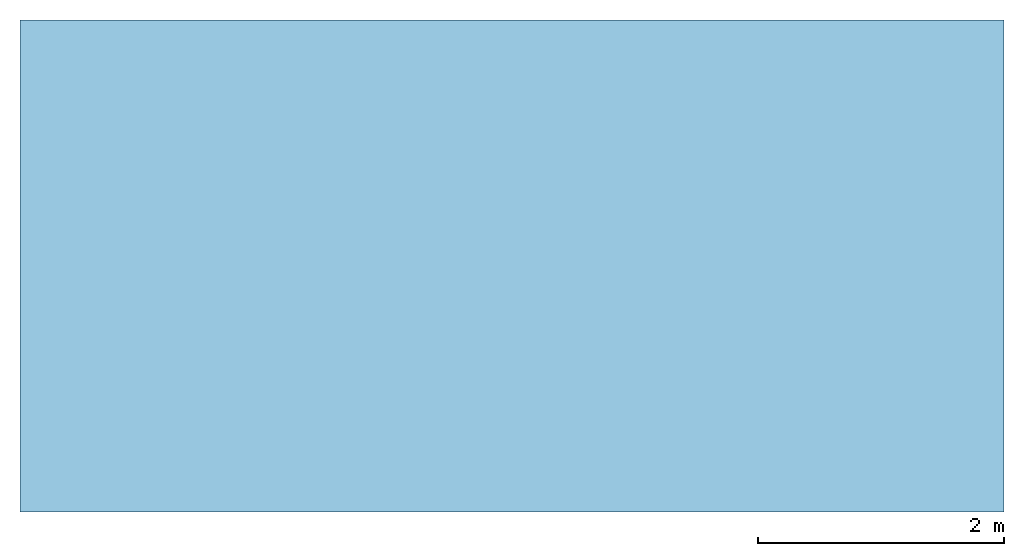
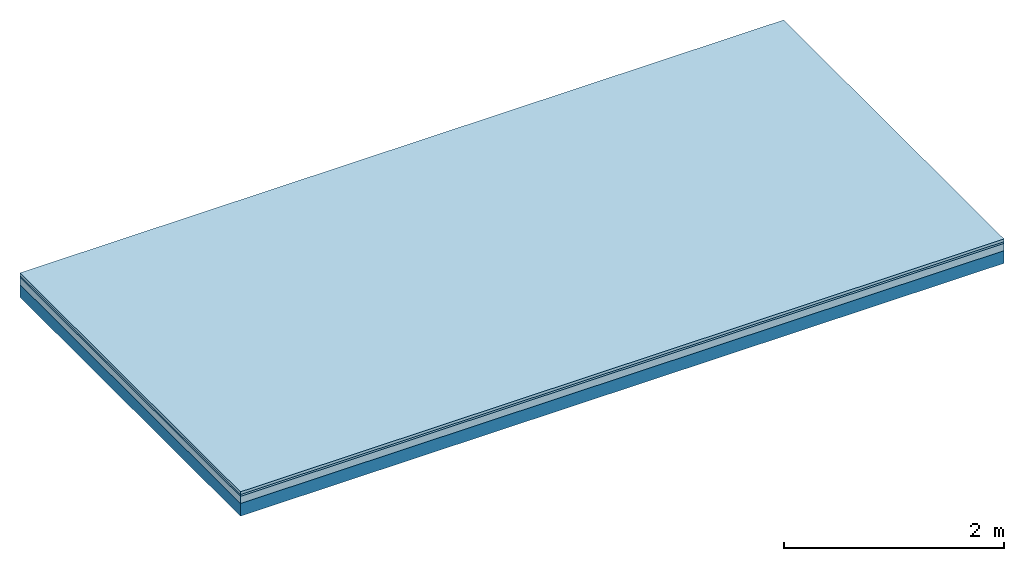
# One storey: 3 plates, 1 member, 1 element without a shape of its own.
"""IFC4 building model written with IfcOpenShell, lengths in metres."""

from ifc_helpers import new_model, si_unit, derived_unit, direction, frame, frame_2d, origin, origin_with_axes, place, context, project, spatial, rectangle, extrude, material, layer, layer_set, type_object, element, aggregate, save


model = new_model("IFC4")

# Units and contexts
plan_context = context("Plan", 3, precision=1e-05, world=origin(), true_north=direction((0.0, 1.0)))
model_context = context("Model", 3, precision=1e-05, world=origin(), true_north=direction((0.0, 1.0)))
ifc_project = project(units=[si_unit("LENGTHUNIT", "METRE"), derived_unit("SOUNDPRESSUREUNIT", [(si_unit("PRESSUREUNIT", "PASCAL", prefix="MICRO"), 0)]), si_unit("ENERGYUNIT", "JOULE", prefix="MEGA"), si_unit("MASSUNIT", "GRAM", prefix="KILO"), derived_unit("THERMALTRANSMITTANCEUNIT", [(si_unit("POWERUNIT", "WATT"), 1), (si_unit("AREAUNIT", "SQUARE_METRE"), -1), (si_unit("THERMODYNAMICTEMPERATUREUNIT", "KELVIN"), -1)]), derived_unit("AREADENSITYUNIT", [(si_unit("MASSUNIT", "GRAM", prefix="KILO"), 1), (si_unit("AREAUNIT", "SQUARE_METRE"), -1)]), derived_unit("USERDEFINED", [(si_unit("ENERGYUNIT", "JOULE", prefix="MEGA"), 1), (si_unit("AREAUNIT", "SQUARE_METRE"), -1)])], contexts=[plan_context, model_context])

# Site, building, storey
site = spatial("IfcSite", under=ifc_project)
building_placement = place(None, origin())
building = spatial("IfcBuilding", under=site, at=building_placement)
storey_placement = place(building_placement, origin())
storey = spatial("IfcBuildingStorey", under=building, at=storey_placement)

# Slab, member, plates
ifc_material_1 = material(Name="Phone Star TRI", Category="03.013")
ifc_layer_1 = layer(ifc_material_1, 0.03, Name="On-material")
ifc_material_2 = material(Name="EP3")
ifc_layer_2 = layer(ifc_material_2, 0.02, Name="Impact sound insulation")
ifc_material_3 = material(Category="03.011")
ifc_layer_3 = layer(ifc_material_3, 0.08, Name="on Supporting structure")
ifc_material_4 = material(Name="no composite action")
ifc_layer_4 = layer(ifc_material_4, 0.0, Name="Bond")
ifc_layer_5 = layer(None, 0.14, Name="Supporting structure")
ifc_layer_set = layer_set([ifc_layer_1, ifc_layer_2, ifc_layer_3, ifc_layer_4, ifc_layer_5])
slab_type = type_object("IfcSlabType", Name="A2424", PredefinedType="NOTDEFINED", material=ifc_layer_set)
slab_placement = place(None, frame((0.0, 0.0, 0.0), z_axis=(0.0, 0.0, -1.0), x_axis=(1.0, 0.0, 0.0)))
slab = element("IfcSlab", 1, at=slab_placement, inside=storey, type_object=slab_type, material=ifc_layer_set, Name="Slab #1")
ifc_material_5 = material()
member_placement = place(slab_placement, origin())
member = element("IfcMember", 2, at=member_placement, material=ifc_material_5, Name="Supporting structure", context=plan_context, shape_type="SweptSolid", body=[
    extrude(rectangle(XDim=1.0, YDim=0.14, at=frame_2d((0.5, 0.07), x_axis=(1.0, 0.0))), frame((0.0, 4.0, 0.13), z_axis=(0.0, -1.0, 0.0), x_axis=(1.0, 0.0, 0.0)), (0.0, 0.0, 1.0), 4.0),
    extrude(rectangle(XDim=1.0, YDim=0.14, at=frame_2d((0.5, 0.07), x_axis=(1.0, 0.0))), frame((1.0, 4.0, 0.13), z_axis=(0.0, -1.0, 0.0), x_axis=(1.0, 0.0, 0.0)), (0.0, 0.0, 1.0), 4.0),
    extrude(rectangle(XDim=1.0, YDim=0.14, at=frame_2d((0.5, 0.07), x_axis=(1.0, 0.0))), frame((2.0, 4.0, 0.13), z_axis=(0.0, -1.0, 0.0), x_axis=(1.0, 0.0, 0.0)), (0.0, 0.0, 1.0), 4.0),
    extrude(rectangle(XDim=1.0, YDim=0.14, at=frame_2d((0.5, 0.07), x_axis=(1.0, 0.0))), frame((3.0, 4.0, 0.13), z_axis=(0.0, -1.0, 0.0), x_axis=(1.0, 0.0, 0.0)), (0.0, 0.0, 1.0), 4.0),
    extrude(rectangle(XDim=1.0, YDim=0.14, at=frame_2d((0.5, 0.07), x_axis=(1.0, 0.0))), frame((4.0, 4.0, 0.13), z_axis=(0.0, -1.0, 0.0), x_axis=(1.0, 0.0, 0.0)), (0.0, 0.0, 1.0), 4.0),
    extrude(rectangle(XDim=1.0, YDim=0.14, at=frame_2d((0.5, 0.07), x_axis=(1.0, 0.0))), frame((5.0, 4.0, 0.13), z_axis=(0.0, -1.0, 0.0), x_axis=(1.0, 0.0, 0.0)), (0.0, 0.0, 1.0), 4.0),
    extrude(rectangle(XDim=1.0, YDim=0.14, at=frame_2d((0.5, 0.07), x_axis=(1.0, 0.0))), frame((6.0, 4.0, 0.13), z_axis=(0.0, -1.0, 0.0), x_axis=(1.0, 0.0, 0.0)), (0.0, 0.0, 1.0), 4.0),
    extrude(rectangle(XDim=1.0, YDim=0.14, at=frame_2d((0.5, 0.07), x_axis=(1.0, 0.0))), frame((7.0, 4.0, 0.13), z_axis=(0.0, -1.0, 0.0), x_axis=(1.0, 0.0, 0.0)), (0.0, 0.0, 1.0), 4.0),
])
plate_1_placement = place(slab_placement, origin())
plate_1 = element("IfcPlate", 3, at=plate_1_placement, material=ifc_material_1, Name="On-material", context=plan_context, shape_type="SweptSolid", body=[
    extrude(rectangle(XDim=8.0, YDim=4.0, at=frame_2d((4.0, 2.0), x_axis=(1.0, 0.0))), origin_with_axes(), (0.0, 0.0, 1.0), 0.03),
])
plate_2_placement = place(slab_placement, origin())
plate_2 = element("IfcPlate", 4, at=plate_2_placement, material=ifc_material_2, Name="Impact sound insulation", context=plan_context, shape_type="SweptSolid", body=[
    extrude(rectangle(XDim=8.0, YDim=4.0, at=frame_2d((4.0, 2.0), x_axis=(1.0, 0.0))), frame((0.0, 0.0, 0.03), z_axis=(0.0, 0.0, 1.0), x_axis=(1.0, 0.0, 0.0)), (0.0, 0.0, 1.0), 0.02),
])
plate_3_placement = place(slab_placement, origin())
plate_3 = element("IfcPlate", 5, at=plate_3_placement, material=ifc_material_3, Name="on Supporting structure", context=plan_context, shape_type="SweptSolid", body=[
    extrude(rectangle(XDim=8.0, YDim=4.0, at=frame_2d((4.0, 2.0), x_axis=(1.0, 0.0))), frame((0.0, 0.0, 0.05), z_axis=(0.0, 0.0, 1.0), x_axis=(1.0, 0.0, 0.0)), (0.0, 0.0, 1.0), 0.08),
])
aggregate(slab, [plate_1, plate_2, plate_3, member])

save(model, "model.ifc")
